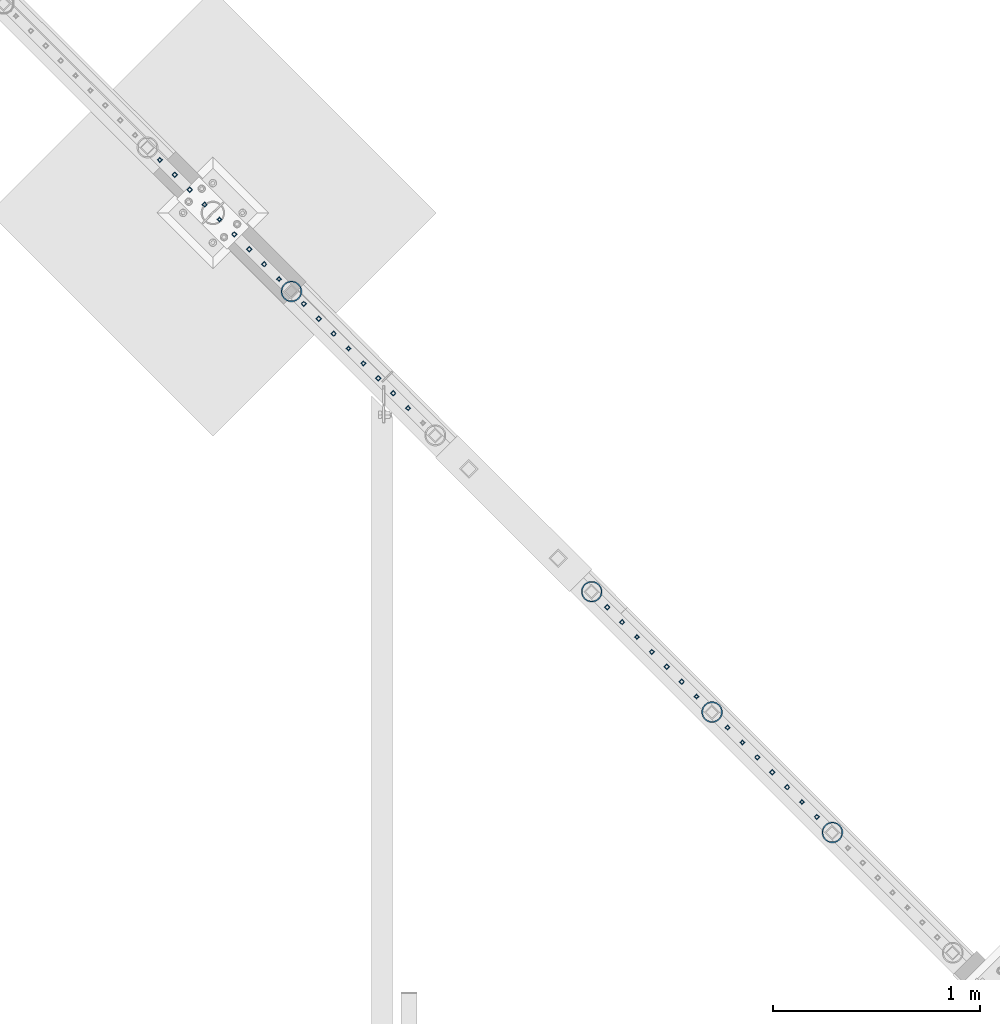
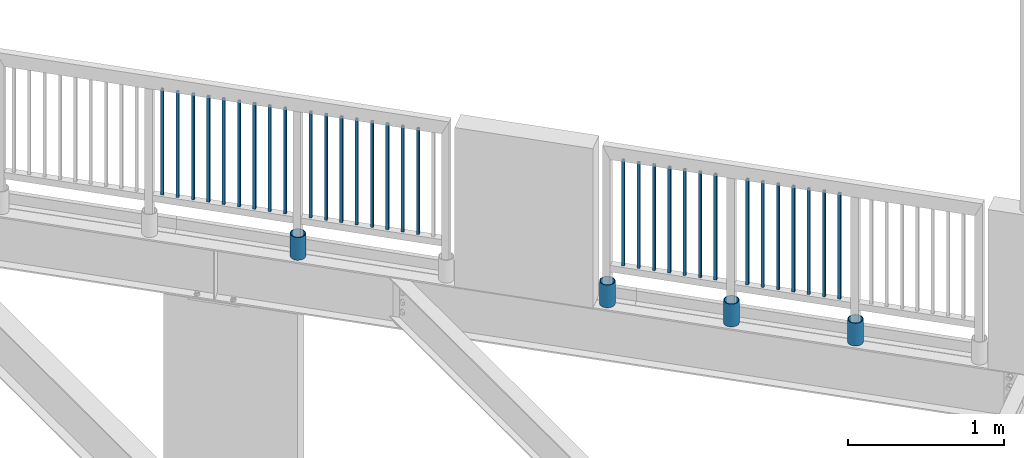
# One storey, part 250 of 975: 35 columns.
"""IFC2X3 building model written with IfcOpenShell, lengths in millimetres."""

from ifc_helpers import new_model, si_unit, frame, origin_with_axes, place, context, subcontext, project, spatial, faceted_brep, material, type_object, element, save


model = new_model("IFC2X3")

# Units and contexts
model_context = context("Model", 3, precision=1e-05, world=origin_with_axes())
body_context = subcontext(model_context, "Body", "Model", "MODEL_VIEW")
ifc_project = project(units=[si_unit("LENGTHUNIT", "METRE", prefix="MILLI"), si_unit("AREAUNIT", "SQUARE_METRE"), si_unit("VOLUMEUNIT", "CUBIC_METRE"), si_unit("MASSUNIT", "GRAM", prefix="KILO"), si_unit("TIMEUNIT", "SECOND"), si_unit("PLANEANGLEUNIT", "RADIAN"), si_unit("SOLIDANGLEUNIT", "STERADIAN"), si_unit("THERMODYNAMICTEMPERATUREUNIT", "DEGREE_CELSIUS"), si_unit("LUMINOUSINTENSITYUNIT", "LUMEN")], contexts=[model_context])

# Site, building, storey
site_placement = place(None, origin_with_axes())
site = spatial("IfcSite", under=ifc_project, at=site_placement, CompositionType="ELEMENT")
building_placement = place(site_placement, origin_with_axes())
building = spatial("IfcBuilding", under=site, at=building_placement, Name="Undefined", CompositionType="ELEMENT")
storey_placement = place(building_placement, origin_with_axes())
storey = spatial("IfcBuildingStorey", under=building, at=storey_placement, Name="Undefined", CompositionType="ELEMENT", Elevation=0.0)

# Columns
ifc_material_1 = material()
column_type_1 = type_object("IfcColumnType", Name="HSS3/4X3/4X.120_TUBES", PredefinedType="NOTDEFINED")
for number, where, z_axis, x_axis, name in (
    (1, (22499.8388246237, 26135.0435777329, 4254.49983907228), (-0.707106781186601, 0.707106781186494, 2.36468622460961e-14), (0.0, 0.0, 1.0), "PICKET"),
    (2, (22571.6731996237, 26063.2092027329, 4254.49983907228), (-0.707106781186601, 0.707106781186494, 2.36468622460961e-14), (0.0, 0.0, 1.0), "PICKET"),
    (3, (22643.5075746237, 25991.3748277329, 4254.49983907228), (-0.707106781186601, 0.707106781186494, 2.36468622460961e-14), (0.0, 0.0, 1.0), "PICKET"),
    (4, (22715.3419496237, 25919.5404527329, 4254.49983907228), (-0.707106781186601, 0.707106781186494, 2.36468622460961e-14), (0.0, 0.0, 1.0), "PICKET"),
    (5, (22787.1763246237, 25847.7060777329, 4254.49983907228), (-0.707106781186601, 0.707106781186494, 2.36468622460961e-14), (0.0, 0.0, 1.0), "PICKET"),
    (6, (22859.0106996237, 25775.8717027329, 4254.49983907228), (-0.707106781186601, 0.707106781186494, 2.36468622460961e-14), (0.0, 0.0, 1.0), "PICKET"),
    (7, (22930.8450746237, 25704.0373277329, 4254.49983907228), (-0.707106781186601, 0.707106781186494, 2.36468622460961e-14), (0.0, 0.0, 1.0), "PICKET"),
    (8, (23002.6794496237, 25632.2029527329, 4254.49983907228), (-0.707106781186601, 0.707106781186494, 2.36468622460961e-14), (0.0, 0.0, 1.0), "PICKET"),
    (9, (23074.5138246237, 25560.3685777329, 4254.49983907228), (-0.707106781186601, 0.707106781186494, 2.36468622460961e-14), (0.0, 0.0, 1.0), "PICKET"),
    (10, (23194.3071548513, 25440.5635701219, 4254.49996006912), (-0.707106781186601, 0.707106781186494, 2.36468622460961e-14), (0.0, 0.0, 1.0), "PICKET"),
    (11, (23266.1415298513, 25368.7291951219, 4254.49996006912), (-0.707106781186601, 0.707106781186494, 2.36468622460961e-14), (0.0, 0.0, 1.0), "PICKET"),
    (12, (23337.9759048513, 25296.8948201219, 4254.49996006912), (-0.707106781186601, 0.707106781186494, 2.36468622460961e-14), (0.0, 0.0, 1.0), "PICKET"),
    (13, (23409.8102798513, 25225.0604451219, 4254.49996006912), (-0.707106781186601, 0.707106781186494, 2.36468622460961e-14), (0.0, 0.0, 1.0), "PICKET"),
    (14, (23481.6446548513, 25153.2260701219, 4254.49996006912), (-0.707106781186601, 0.707106781186494, 2.36468622460961e-14), (0.0, 0.0, 1.0), "PICKET"),
    (15, (23553.4790298513, 25081.3916951219, 4254.49996006912), (-0.707106781186601, 0.707106781186494, 2.36468622460961e-14), (0.0, 0.0, 1.0), "PICKET"),
    (16, (23625.3134048513, 25009.5573201219, 4254.49996006912), (-0.707106781186601, 0.707106781186494, 2.36468622460961e-14), (0.0, 0.0, 1.0), "PICKET"),
    (17, (23697.1477798513, 24937.7229451219, 4254.49996006912), (-0.707106781186601, 0.707106781186494, 2.36468622460961e-14), (0.0, 0.0, 1.0), "PICKET"),
    (18, (24658.0331738141, 23976.7508869886, 4254.49884741113), (-0.707106781186601, 0.707106781186494, 2.36468622460961e-14), (0.0, 0.0, 1.0), "PICKET"),
    (19, (24729.8675488141, 23904.9165119886, 4254.49884741113), (-0.707106781186601, 0.707106781186494, 2.36468622460961e-14), (0.0, 0.0, 1.0), "PICKET"),
    (20, (24801.7019238141, 23833.0821369886, 4254.49884741113), (-0.707106781186601, 0.707106781186494, 2.36468622460961e-14), (0.0, 0.0, 1.0), "PICKET"),
    (21, (24873.5362988141, 23761.2477619886, 4254.49884741113), (-0.707106781186601, 0.707106781186494, 2.36468622460961e-14), (0.0, 0.0, 1.0), "PICKET"),
    (22, (24945.3706738141, 23689.4133869886, 4254.49884741113), (-0.707106781186601, 0.707106781186494, 2.36468622460961e-14), (0.0, 0.0, 1.0), "PICKET"),
    (23, (25017.2050488141, 23617.5790119886, 4254.49884741113), (-0.707106781186601, 0.707106781186494, 2.36468622460961e-14), (0.0, 0.0, 1.0), "PICKET"),
    (24, (25089.0394238141, 23545.7446369886, 4254.49884741113), (-0.707106781186601, 0.707106781186494, 2.36468622460961e-14), (0.0, 0.0, 1.0), "PICKET"),
    (25, (25238.7501837319, 23396.0192833541, 4254.49892301854), (-0.707106781186601, 0.707106781186494, 2.36468622460961e-14), (0.0, 0.0, 1.0), "PICKET"),
    (26, (25310.5845587319, 23324.1849083541, 4254.49892301854), (-0.707106781186601, 0.707106781186494, 2.36468622460961e-14), (0.0, 0.0, 1.0), "PICKET"),
    (27, (25382.4189337319, 23252.3505333541, 4254.49892301854), (-0.707106781186601, 0.707106781186494, 2.36468622460961e-14), (0.0, 0.0, 1.0), "PICKET"),
    (28, (25454.2533087319, 23180.5161583541, 4254.49892301854), (-0.707106781186601, 0.707106781186494, 2.36468622460961e-14), (0.0, 0.0, 1.0), "PICKET"),
    (29, (25526.0876837319, 23108.6817833541, 4254.49892301854), (-0.707106781186601, 0.707106781186494, 2.36468622460961e-14), (0.0, 0.0, 1.0), "PICKET"),
    (30, (25597.9220587319, 23036.8474083541, 4254.49892301854), (-0.707106781186601, 0.707106781186494, 2.36468622460961e-14), (0.0, 0.0, 1.0), "PICKET"),
    (31, (25669.7564337319, 22965.0130333541, 4254.49892301854), (-0.707106781186601, 0.707106781186494, 2.36468622460961e-14), (0.0, 0.0, 1.0), "PICKET"),
):
    element("IfcColumn", number, at=place(storey_placement, frame(where, z_axis=z_axis, x_axis=x_axis)), inside=storey, type_object=column_type_1, material=ifc_material_1, Name=name, ObjectType="HSS3/4X3/4X.120_TUBES", context=body_context, shape_type="Brep", body=[
        faceted_brep([(0.0, 6.34999999998763, -6.34999999998763), (0.0, -6.35000000000582, -6.34999999998763), (825.49997943247, -6.35000000000582, -6.34999999998763), (825.49997943247, 6.34999999998763, -6.34999999998763), (0.0, -6.34999999998763, 6.34999999998763), (825.49997943247, -6.34999999998763, 6.34999999998763), (0.0, 6.35000000000946, 6.34999999998763), (825.49997943247, 6.35000000000946, 6.34999999998763), (0.0, 9.52499999997963, -9.52499999997963), (0.0, 9.52500000000873, 9.5249999999869), (825.49997943247, 9.52500000000873, 9.5249999999869), (825.49997943247, 9.52499999997963, -9.52499999997963), (0.0, -9.52499999997963, 9.52499999998327), (825.49997943247, -9.52499999997963, 9.52499999998327), (0.0, -9.52500000000873, -9.5249999999869), (825.49997943247, -9.52500000000873, -9.5249999999869)], [[[0, 1, 2, 3]], [[1, 4, 5, 2]], [[4, 6, 7, 5]], [[6, 0, 3, 7]], [[8, 9, 10, 11]], [[9, 12, 13, 10]], [[12, 14, 15, 13]], [[14, 8, 11, 15]], [[13, 15, 11, 10], [5, 7, 3, 2]], [[14, 12, 9, 8], [6, 4, 1, 0]]]),
    ])
ifc_material_2 = material(Name="STEEL/A53")
column_type_2 = type_object("IfcColumnType", Name="PIPE3-1/2STD", PredefinedType="NOTDEFINED")
column_1_placement = place(storey_placement, frame((25744.4987497212, 22890.0361789292, 3937.0), z_axis=(-0.707106781186601, 0.707106781186494, 2.36468622460961e-14), x_axis=(0.0, 0.0, 1.0)))
element("IfcColumn", 32, at=column_1_placement, inside=storey, type_object=column_type_2, material=ifc_material_2, ObjectType="PIPE3-1/2STD", context=body_context, shape_type="Brep", body=[
    faceted_brep([(0.0, -45.0595999999932, 1.45519152283669e-11), (0.0, -42.8542262016344, 13.924182159768), (177.8, -42.8542262016344, 13.924182159768), (177.8, -45.0595999999932, 1.45519152283669e-11), (0.0, -36.45398215971, 26.4853683542424), (177.8, -36.45398215971, 26.4853683542424), (0.0, -26.4853683541623, 36.45398215979), (177.8, -26.4853683541623, 36.45398215979), (0.0, -13.9241821596988, 42.8542262017108), (177.8, -13.9241821596988, 42.8542262017108), (0.0, 3.63797880709171e-11, 45.0596000000514), (177.8, 3.63797880709171e-11, 45.0596000000514), (0.0, 13.9241821597716, 42.8542262017036), (177.8, 13.9241821597716, 42.8542262017036), (0.0, 26.4853683542242, 36.4539821597718), (177.8, 26.4853683542242, 36.4539821597718), (0.0, 36.4539821597537, 26.4853683542206), (177.8, 36.4539821597537, 26.4853683542206), (0.0, 42.8542262016563, 13.9241821597425), (177.8, 42.8542262016563, 13.9241821597425), (0.0, 45.0595999999932, -1.09139364212751e-11), (177.8, 45.0595999999932, -1.09139364212751e-11), (0.0, 42.8542262016344, -13.9241821597643), (177.8, 42.8542262016344, -13.9241821597643), (0.0, 36.45398215971, -26.4853683542387), (177.8, 36.45398215971, -26.4853683542387), (0.0, 26.4853683541623, -36.4539821597864), (177.8, 26.4853683541623, -36.4539821597864), (0.0, 13.9241821596988, -42.8542262017072), (177.8, 13.9241821596988, -42.8542262017072), (0.0, -3.63797880709171e-11, -45.0596000000478), (177.8, -3.63797880709171e-11, -45.0596000000478), (0.0, -13.9241821597716, -42.8542262016963), (177.8, -13.9241821597716, -42.8542262016963), (0.0, -26.4853683542242, -36.4539821597682), (177.8, -26.4853683542242, -36.4539821597682), (0.0, -36.4539821597537, -26.4853683542169), (177.8, -36.4539821597537, -26.4853683542169), (0.0, -42.8542262016563, -13.9241821597352), (177.8, -42.8542262016563, -13.9241821597352), (0.0, -50.799999999992, 1.81898940354586e-11), (0.0, -48.3136710278013, -15.6980633142484), (177.8, -48.3136710278013, -15.6980633142484), (177.8, -50.799999999992, 1.81898940354586e-11), (0.0, -41.0980633142644, -29.8594908164741), (177.8, -41.0980633142644, -29.8594908164741), (0.0, -29.859490816485, -41.0980633142826), (177.8, -29.859490816485, -41.0980633142826), (0.0, -15.6980633142848, -48.313671027845), (177.8, -15.6980633142848, -48.313671027845), (0.0, -4.36557456851006e-11, -50.8000000000575), (177.8, -4.36557456851006e-11, -50.8000000000575), (0.0, 15.6980633142011, -48.3136710278523), (177.8, 15.6980633142011, -48.3136710278523), (0.0, 29.8594908164159, -41.0980633143045), (177.8, 29.8594908164159, -41.0980633143045), (0.0, 41.0980633142135, -29.8594908165032), (177.8, 41.0980633142135, -29.8594908165032), (0.0, 48.3136710277722, -15.6980633142775), (177.8, 48.3136710277722, -15.6980633142775), (0.0, 50.799999999992, -1.45519152283669e-11), (177.8, 50.799999999992, -1.45519152283669e-11), (0.0, 48.313671027794, 15.6980633142521), (177.8, 48.313671027794, 15.6980633142521), (0.0, 41.0980633142644, 29.8594908164814), (177.8, 41.0980633142644, 29.8594908164814), (0.0, 29.859490816485, 41.0980633142863), (177.8, 29.859490816485, 41.0980633142863), (0.0, 15.6980633142848, 48.3136710278486), (177.8, 15.6980633142848, 48.3136710278486), (0.0, 4.00177668780088e-11, 50.8000000000611), (177.8, 4.00177668780088e-11, 50.8000000000611), (0.0, -15.6980633142011, 48.3136710278559), (177.8, -15.6980633142011, 48.3136710278559), (0.0, -29.8594908164159, 41.0980633143081), (177.8, -29.8594908164159, 41.0980633143081), (0.0, -41.0980633142171, 29.8594908165069), (177.8, -41.0980633142171, 29.8594908165069), (0.0, -48.3136710277722, 15.6980633142812), (177.8, -48.3136710277722, 15.6980633142812)], [[[0, 1, 2, 3]], [[1, 4, 5, 2]], [[4, 6, 7, 5]], [[6, 8, 9, 7]], [[8, 10, 11, 9]], [[10, 12, 13, 11]], [[12, 14, 15, 13]], [[14, 16, 17, 15]], [[16, 18, 19, 17]], [[18, 20, 21, 19]], [[20, 22, 23, 21]], [[22, 24, 25, 23]], [[24, 26, 27, 25]], [[26, 28, 29, 27]], [[28, 30, 31, 29]], [[30, 32, 33, 31]], [[32, 34, 35, 33]], [[34, 36, 37, 35]], [[36, 38, 39, 37]], [[38, 0, 3, 39]], [[40, 41, 42, 43]], [[41, 44, 45, 42]], [[44, 46, 47, 45]], [[46, 48, 49, 47]], [[48, 50, 51, 49]], [[50, 52, 53, 51]], [[52, 54, 55, 53]], [[54, 56, 57, 55]], [[56, 58, 59, 57]], [[58, 60, 61, 59]], [[60, 62, 63, 61]], [[62, 64, 65, 63]], [[64, 66, 67, 65]], [[66, 68, 69, 67]], [[68, 70, 71, 69]], [[70, 72, 73, 71]], [[72, 74, 75, 73]], [[74, 76, 77, 75]], [[76, 78, 79, 77]], [[78, 40, 43, 79]], [[45, 47, 49, 51, 53, 55, 57, 59, 61, 63, 65, 67, 69, 71, 73, 75, 77, 79, 43, 42], [5, 7, 9, 11, 13, 15, 17, 19, 21, 23, 25, 27, 29, 31, 33, 35, 37, 39, 3, 2]], [[78, 76, 74, 72, 70, 68, 66, 64, 62, 60, 58, 56, 54, 52, 50, 48, 46, 44, 41, 40], [38, 36, 34, 32, 30, 28, 26, 24, 22, 20, 18, 16, 14, 12, 10, 8, 6, 4, 1, 0]]]),
])
column_2_placement = place(storey_placement, frame((25163.7973154506, 23470.7822770541, 3937.0), z_axis=(-0.707106781186601, 0.707106781186494, 2.36468622460961e-14), x_axis=(0.0, 0.0, 1.0)))
element("IfcColumn", 33, at=column_2_placement, inside=storey, type_object=column_type_2, material=ifc_material_2, ObjectType="PIPE3-1/2STD", context=body_context, shape_type="Brep", body=[
    faceted_brep([(0.0, -45.0595999999932, 1.45519152283669e-11), (0.0, -42.8542262016344, 13.924182159768), (177.8, -42.8542262016344, 13.924182159768), (177.8, -45.0595999999932, 1.45519152283669e-11), (0.0, -36.45398215971, 26.4853683542424), (177.8, -36.45398215971, 26.4853683542424), (0.0, -26.4853683541623, 36.45398215979), (177.8, -26.4853683541623, 36.45398215979), (0.0, -13.9241821596988, 42.8542262017108), (177.8, -13.9241821596988, 42.8542262017108), (0.0, 3.63797880709171e-11, 45.0596000000514), (177.8, 3.63797880709171e-11, 45.0596000000514), (0.0, 13.9241821597716, 42.8542262017036), (177.8, 13.9241821597716, 42.8542262017036), (0.0, 26.4853683542242, 36.4539821597718), (177.8, 26.4853683542242, 36.4539821597718), (0.0, 36.4539821597537, 26.4853683542206), (177.8, 36.4539821597537, 26.4853683542206), (0.0, 42.8542262016563, 13.9241821597425), (177.8, 42.8542262016563, 13.9241821597425), (0.0, 45.0595999999932, -1.09139364212751e-11), (177.8, 45.0595999999932, -1.09139364212751e-11), (0.0, 42.8542262016344, -13.9241821597643), (177.8, 42.8542262016344, -13.9241821597643), (0.0, 36.45398215971, -26.4853683542387), (177.8, 36.45398215971, -26.4853683542387), (0.0, 26.4853683541623, -36.4539821597864), (177.8, 26.4853683541623, -36.4539821597864), (0.0, 13.9241821596988, -42.8542262017072), (177.8, 13.9241821596988, -42.8542262017072), (0.0, -3.63797880709171e-11, -45.0596000000478), (177.8, -3.63797880709171e-11, -45.0596000000478), (0.0, -13.9241821597716, -42.8542262016963), (177.8, -13.9241821597716, -42.8542262016963), (0.0, -26.4853683542242, -36.4539821597682), (177.8, -26.4853683542242, -36.4539821597682), (0.0, -36.4539821597537, -26.4853683542169), (177.8, -36.4539821597537, -26.4853683542169), (0.0, -42.8542262016563, -13.9241821597352), (177.8, -42.8542262016563, -13.9241821597352), (0.0, -50.799999999992, 1.81898940354586e-11), (0.0, -48.3136710278013, -15.6980633142484), (177.8, -48.3136710278013, -15.6980633142484), (177.8, -50.799999999992, 1.81898940354586e-11), (0.0, -41.0980633142644, -29.8594908164741), (177.8, -41.0980633142644, -29.8594908164741), (0.0, -29.859490816485, -41.0980633142826), (177.8, -29.859490816485, -41.0980633142826), (0.0, -15.6980633142848, -48.313671027845), (177.8, -15.6980633142848, -48.313671027845), (0.0, -4.36557456851006e-11, -50.8000000000575), (177.8, -4.36557456851006e-11, -50.8000000000575), (0.0, 15.6980633142011, -48.3136710278523), (177.8, 15.6980633142011, -48.3136710278523), (0.0, 29.8594908164159, -41.0980633143045), (177.8, 29.8594908164159, -41.0980633143045), (0.0, 41.0980633142135, -29.8594908165032), (177.8, 41.0980633142135, -29.8594908165032), (0.0, 48.3136710277722, -15.6980633142775), (177.8, 48.3136710277722, -15.6980633142775), (0.0, 50.799999999992, -1.45519152283669e-11), (177.8, 50.799999999992, -1.45519152283669e-11), (0.0, 48.313671027794, 15.6980633142521), (177.8, 48.313671027794, 15.6980633142521), (0.0, 41.0980633142644, 29.8594908164814), (177.8, 41.0980633142644, 29.8594908164814), (0.0, 29.859490816485, 41.0980633142863), (177.8, 29.859490816485, 41.0980633142863), (0.0, 15.6980633142848, 48.3136710278486), (177.8, 15.6980633142848, 48.3136710278486), (0.0, 4.00177668780088e-11, 50.8000000000611), (177.8, 4.00177668780088e-11, 50.8000000000611), (0.0, -15.6980633142011, 48.3136710278559), (177.8, -15.6980633142011, 48.3136710278559), (0.0, -29.8594908164159, 41.0980633143081), (177.8, -29.8594908164159, 41.0980633143081), (0.0, -41.0980633142171, 29.8594908165069), (177.8, -41.0980633142171, 29.8594908165069), (0.0, -48.3136710277722, 15.6980633142812), (177.8, -48.3136710277722, 15.6980633142812)], [[[0, 1, 2, 3]], [[1, 4, 5, 2]], [[4, 6, 7, 5]], [[6, 8, 9, 7]], [[8, 10, 11, 9]], [[10, 12, 13, 11]], [[12, 14, 15, 13]], [[14, 16, 17, 15]], [[16, 18, 19, 17]], [[18, 20, 21, 19]], [[20, 22, 23, 21]], [[22, 24, 25, 23]], [[24, 26, 27, 25]], [[26, 28, 29, 27]], [[28, 30, 31, 29]], [[30, 32, 33, 31]], [[32, 34, 35, 33]], [[34, 36, 37, 35]], [[36, 38, 39, 37]], [[38, 0, 3, 39]], [[40, 41, 42, 43]], [[41, 44, 45, 42]], [[44, 46, 47, 45]], [[46, 48, 49, 47]], [[48, 50, 51, 49]], [[50, 52, 53, 51]], [[52, 54, 55, 53]], [[54, 56, 57, 55]], [[56, 58, 59, 57]], [[58, 60, 61, 59]], [[60, 62, 63, 61]], [[62, 64, 65, 63]], [[64, 66, 67, 65]], [[66, 68, 69, 67]], [[68, 70, 71, 69]], [[70, 72, 73, 71]], [[72, 74, 75, 73]], [[74, 76, 77, 75]], [[76, 78, 79, 77]], [[78, 40, 43, 79]], [[45, 47, 49, 51, 53, 55, 57, 59, 61, 63, 65, 67, 69, 71, 73, 75, 77, 79, 43, 42], [5, 7, 9, 11, 13, 15, 17, 19, 21, 23, 25, 27, 29, 31, 33, 35, 37, 39, 3, 2]], [[78, 76, 74, 72, 70, 68, 66, 64, 62, 60, 58, 56, 54, 52, 50, 48, 46, 44, 41, 40], [38, 36, 34, 32, 30, 28, 26, 24, 22, 20, 18, 16, 14, 12, 10, 8, 6, 4, 1, 0]]]),
])
column_3_placement = place(storey_placement, frame((23134.3320406308, 25500.5492293901, 3937.0), z_axis=(-0.707106781186601, 0.707106781186494, 2.36468622460961e-14), x_axis=(0.0, 0.0, 1.0)))
element("IfcColumn", 34, at=column_3_placement, inside=storey, type_object=column_type_2, material=ifc_material_2, ObjectType="PIPE3-1/2STD", context=body_context, shape_type="Brep", body=[
    faceted_brep([(0.0, -45.0595999999932, 1.45519152283669e-11), (0.0, -42.8542262016344, 13.924182159768), (177.8, -42.8542262016344, 13.924182159768), (177.8, -45.0595999999932, 1.45519152283669e-11), (0.0, -36.45398215971, 26.4853683542424), (177.8, -36.45398215971, 26.4853683542424), (0.0, -26.4853683541623, 36.45398215979), (177.8, -26.4853683541623, 36.45398215979), (0.0, -13.9241821596988, 42.8542262017108), (177.8, -13.9241821596988, 42.8542262017108), (0.0, 3.63797880709171e-11, 45.0596000000514), (177.8, 3.63797880709171e-11, 45.0596000000514), (0.0, 13.9241821597716, 42.8542262017036), (177.8, 13.9241821597716, 42.8542262017036), (0.0, 26.4853683542242, 36.4539821597718), (177.8, 26.4853683542242, 36.4539821597718), (0.0, 36.4539821597537, 26.4853683542206), (177.8, 36.4539821597537, 26.4853683542206), (0.0, 42.8542262016563, 13.9241821597425), (177.8, 42.8542262016563, 13.9241821597425), (0.0, 45.0595999999932, -1.09139364212751e-11), (177.8, 45.0595999999932, -1.09139364212751e-11), (0.0, 42.8542262016344, -13.9241821597643), (177.8, 42.8542262016344, -13.9241821597643), (0.0, 36.45398215971, -26.4853683542387), (177.8, 36.45398215971, -26.4853683542387), (0.0, 26.4853683541623, -36.4539821597864), (177.8, 26.4853683541623, -36.4539821597864), (0.0, 13.9241821596988, -42.8542262017072), (177.8, 13.9241821596988, -42.8542262017072), (0.0, -3.63797880709171e-11, -45.0596000000478), (177.8, -3.63797880709171e-11, -45.0596000000478), (0.0, -13.9241821597716, -42.8542262016963), (177.8, -13.9241821597716, -42.8542262016963), (0.0, -26.4853683542242, -36.4539821597682), (177.8, -26.4853683542242, -36.4539821597682), (0.0, -36.4539821597537, -26.4853683542169), (177.8, -36.4539821597537, -26.4853683542169), (0.0, -42.8542262016563, -13.9241821597352), (177.8, -42.8542262016563, -13.9241821597352), (0.0, -50.799999999992, 1.81898940354586e-11), (0.0, -48.3136710278013, -15.6980633142484), (177.8, -48.3136710278013, -15.6980633142484), (177.8, -50.799999999992, 1.81898940354586e-11), (0.0, -41.0980633142644, -29.8594908164741), (177.8, -41.0980633142644, -29.8594908164741), (0.0, -29.859490816485, -41.0980633142826), (177.8, -29.859490816485, -41.0980633142826), (0.0, -15.6980633142848, -48.313671027845), (177.8, -15.6980633142848, -48.313671027845), (0.0, -4.36557456851006e-11, -50.8000000000575), (177.8, -4.36557456851006e-11, -50.8000000000575), (0.0, 15.6980633142011, -48.3136710278523), (177.8, 15.6980633142011, -48.3136710278523), (0.0, 29.8594908164159, -41.0980633143045), (177.8, 29.8594908164159, -41.0980633143045), (0.0, 41.0980633142135, -29.8594908165032), (177.8, 41.0980633142135, -29.8594908165032), (0.0, 48.3136710277722, -15.6980633142775), (177.8, 48.3136710277722, -15.6980633142775), (0.0, 50.799999999992, -1.45519152283669e-11), (177.8, 50.799999999992, -1.45519152283669e-11), (0.0, 48.313671027794, 15.6980633142521), (177.8, 48.313671027794, 15.6980633142521), (0.0, 41.0980633142644, 29.8594908164814), (177.8, 41.0980633142644, 29.8594908164814), (0.0, 29.859490816485, 41.0980633142863), (177.8, 29.859490816485, 41.0980633142863), (0.0, 15.6980633142848, 48.3136710278486), (177.8, 15.6980633142848, 48.3136710278486), (0.0, 4.00177668780088e-11, 50.8000000000611), (177.8, 4.00177668780088e-11, 50.8000000000611), (0.0, -15.6980633142011, 48.3136710278559), (177.8, -15.6980633142011, 48.3136710278559), (0.0, -29.8594908164159, 41.0980633143081), (177.8, -29.8594908164159, 41.0980633143081), (0.0, -41.0980633142171, 29.8594908165069), (177.8, -41.0980633142171, 29.8594908165069), (0.0, -48.3136710277722, 15.6980633142812), (177.8, -48.3136710277722, 15.6980633142812)], [[[0, 1, 2, 3]], [[1, 4, 5, 2]], [[4, 6, 7, 5]], [[6, 8, 9, 7]], [[8, 10, 11, 9]], [[10, 12, 13, 11]], [[12, 14, 15, 13]], [[14, 16, 17, 15]], [[16, 18, 19, 17]], [[18, 20, 21, 19]], [[20, 22, 23, 21]], [[22, 24, 25, 23]], [[24, 26, 27, 25]], [[26, 28, 29, 27]], [[28, 30, 31, 29]], [[30, 32, 33, 31]], [[32, 34, 35, 33]], [[34, 36, 37, 35]], [[36, 38, 39, 37]], [[38, 0, 3, 39]], [[40, 41, 42, 43]], [[41, 44, 45, 42]], [[44, 46, 47, 45]], [[46, 48, 49, 47]], [[48, 50, 51, 49]], [[50, 52, 53, 51]], [[52, 54, 55, 53]], [[54, 56, 57, 55]], [[56, 58, 59, 57]], [[58, 60, 61, 59]], [[60, 62, 63, 61]], [[62, 64, 65, 63]], [[64, 66, 67, 65]], [[66, 68, 69, 67]], [[68, 70, 71, 69]], [[70, 72, 73, 71]], [[72, 74, 75, 73]], [[74, 76, 77, 75]], [[76, 78, 79, 77]], [[78, 40, 43, 79]], [[45, 47, 49, 51, 53, 55, 57, 59, 61, 63, 65, 67, 69, 71, 73, 75, 77, 79, 43, 42], [5, 7, 9, 11, 13, 15, 17, 19, 21, 23, 25, 27, 29, 31, 33, 35, 37, 39, 3, 2]], [[78, 76, 74, 72, 70, 68, 66, 64, 62, 60, 58, 56, 54, 52, 50, 48, 46, 44, 41, 40], [38, 36, 34, 32, 30, 28, 26, 24, 22, 20, 18, 16, 14, 12, 10, 8, 6, 4, 1, 0]]]),
])
column_4_placement = place(storey_placement, frame((24583.2385690321, 24051.837109859, 3937.0), z_axis=(-0.707106781186601, 0.707106781186494, 2.36468622460961e-14), x_axis=(0.0, 0.0, 1.0)))
element("IfcColumn", 35, at=column_4_placement, inside=storey, type_object=column_type_2, material=ifc_material_2, ObjectType="PIPE3-1/2STD", context=body_context, shape_type="Brep", body=[
    faceted_brep([(0.0, -45.0595999999932, 1.45519152283669e-11), (0.0, -42.8542262016344, 13.924182159768), (177.8, -42.8542262016344, 13.924182159768), (177.8, -45.0595999999932, 1.45519152283669e-11), (0.0, -36.45398215971, 26.4853683542424), (177.8, -36.45398215971, 26.4853683542424), (0.0, -26.4853683541623, 36.45398215979), (177.8, -26.4853683541623, 36.45398215979), (0.0, -13.9241821596988, 42.8542262017108), (177.8, -13.9241821596988, 42.8542262017108), (0.0, 3.63797880709171e-11, 45.0596000000514), (177.8, 3.63797880709171e-11, 45.0596000000514), (0.0, 13.9241821597716, 42.8542262017036), (177.8, 13.9241821597716, 42.8542262017036), (0.0, 26.4853683542242, 36.4539821597718), (177.8, 26.4853683542242, 36.4539821597718), (0.0, 36.4539821597537, 26.4853683542206), (177.8, 36.4539821597537, 26.4853683542206), (0.0, 42.8542262016563, 13.9241821597425), (177.8, 42.8542262016563, 13.9241821597425), (0.0, 45.0595999999932, -1.09139364212751e-11), (177.8, 45.0595999999932, -1.09139364212751e-11), (0.0, 42.8542262016344, -13.9241821597643), (177.8, 42.8542262016344, -13.9241821597643), (0.0, 36.45398215971, -26.4853683542387), (177.8, 36.45398215971, -26.4853683542387), (0.0, 26.4853683541623, -36.4539821597864), (177.8, 26.4853683541623, -36.4539821597864), (0.0, 13.9241821596988, -42.8542262017072), (177.8, 13.9241821596988, -42.8542262017072), (0.0, -3.63797880709171e-11, -45.0596000000478), (177.8, -3.63797880709171e-11, -45.0596000000478), (0.0, -13.9241821597716, -42.8542262016963), (177.8, -13.9241821597716, -42.8542262016963), (0.0, -26.4853683542242, -36.4539821597682), (177.8, -26.4853683542242, -36.4539821597682), (0.0, -36.4539821597537, -26.4853683542169), (177.8, -36.4539821597537, -26.4853683542169), (0.0, -42.8542262016563, -13.9241821597352), (177.8, -42.8542262016563, -13.9241821597352), (0.0, -50.799999999992, 1.81898940354586e-11), (0.0, -48.3136710278013, -15.6980633142484), (177.8, -48.3136710278013, -15.6980633142484), (177.8, -50.799999999992, 1.81898940354586e-11), (0.0, -41.0980633142644, -29.8594908164741), (177.8, -41.0980633142644, -29.8594908164741), (0.0, -29.859490816485, -41.0980633142826), (177.8, -29.859490816485, -41.0980633142826), (0.0, -15.6980633142848, -48.313671027845), (177.8, -15.6980633142848, -48.313671027845), (0.0, -4.36557456851006e-11, -50.8000000000575), (177.8, -4.36557456851006e-11, -50.8000000000575), (0.0, 15.6980633142011, -48.3136710278523), (177.8, 15.6980633142011, -48.3136710278523), (0.0, 29.8594908164159, -41.0980633143045), (177.8, 29.8594908164159, -41.0980633143045), (0.0, 41.0980633142135, -29.8594908165032), (177.8, 41.0980633142135, -29.8594908165032), (0.0, 48.3136710277722, -15.6980633142775), (177.8, 48.3136710277722, -15.6980633142775), (0.0, 50.799999999992, -1.45519152283669e-11), (177.8, 50.799999999992, -1.45519152283669e-11), (0.0, 48.313671027794, 15.6980633142521), (177.8, 48.313671027794, 15.6980633142521), (0.0, 41.0980633142644, 29.8594908164814), (177.8, 41.0980633142644, 29.8594908164814), (0.0, 29.859490816485, 41.0980633142863), (177.8, 29.859490816485, 41.0980633142863), (0.0, 15.6980633142848, 48.3136710278486), (177.8, 15.6980633142848, 48.3136710278486), (0.0, 4.00177668780088e-11, 50.8000000000611), (177.8, 4.00177668780088e-11, 50.8000000000611), (0.0, -15.6980633142011, 48.3136710278559), (177.8, -15.6980633142011, 48.3136710278559), (0.0, -29.8594908164159, 41.0980633143081), (177.8, -29.8594908164159, 41.0980633143081), (0.0, -41.0980633142171, 29.8594908165069), (177.8, -41.0980633142171, 29.8594908165069), (0.0, -48.3136710277722, 15.6980633142812), (177.8, -48.3136710277722, 15.6980633142812)], [[[0, 1, 2, 3]], [[1, 4, 5, 2]], [[4, 6, 7, 5]], [[6, 8, 9, 7]], [[8, 10, 11, 9]], [[10, 12, 13, 11]], [[12, 14, 15, 13]], [[14, 16, 17, 15]], [[16, 18, 19, 17]], [[18, 20, 21, 19]], [[20, 22, 23, 21]], [[22, 24, 25, 23]], [[24, 26, 27, 25]], [[26, 28, 29, 27]], [[28, 30, 31, 29]], [[30, 32, 33, 31]], [[32, 34, 35, 33]], [[34, 36, 37, 35]], [[36, 38, 39, 37]], [[38, 0, 3, 39]], [[40, 41, 42, 43]], [[41, 44, 45, 42]], [[44, 46, 47, 45]], [[46, 48, 49, 47]], [[48, 50, 51, 49]], [[50, 52, 53, 51]], [[52, 54, 55, 53]], [[54, 56, 57, 55]], [[56, 58, 59, 57]], [[58, 60, 61, 59]], [[60, 62, 63, 61]], [[62, 64, 65, 63]], [[64, 66, 67, 65]], [[66, 68, 69, 67]], [[68, 70, 71, 69]], [[70, 72, 73, 71]], [[72, 74, 75, 73]], [[74, 76, 77, 75]], [[76, 78, 79, 77]], [[78, 40, 43, 79]], [[45, 47, 49, 51, 53, 55, 57, 59, 61, 63, 65, 67, 69, 71, 73, 75, 77, 79, 43, 42], [5, 7, 9, 11, 13, 15, 17, 19, 21, 23, 25, 27, 29, 31, 33, 35, 37, 39, 3, 2]], [[78, 76, 74, 72, 70, 68, 66, 64, 62, 60, 58, 56, 54, 52, 50, 48, 46, 44, 41, 40], [38, 36, 34, 32, 30, 28, 26, 24, 22, 20, 18, 16, 14, 12, 10, 8, 6, 4, 1, 0]]]),
])

save(model, "model.ifc")
